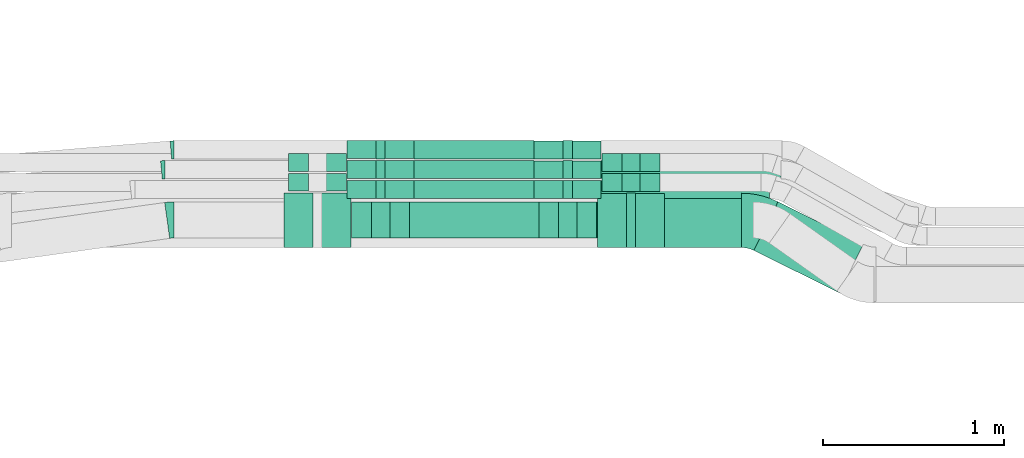
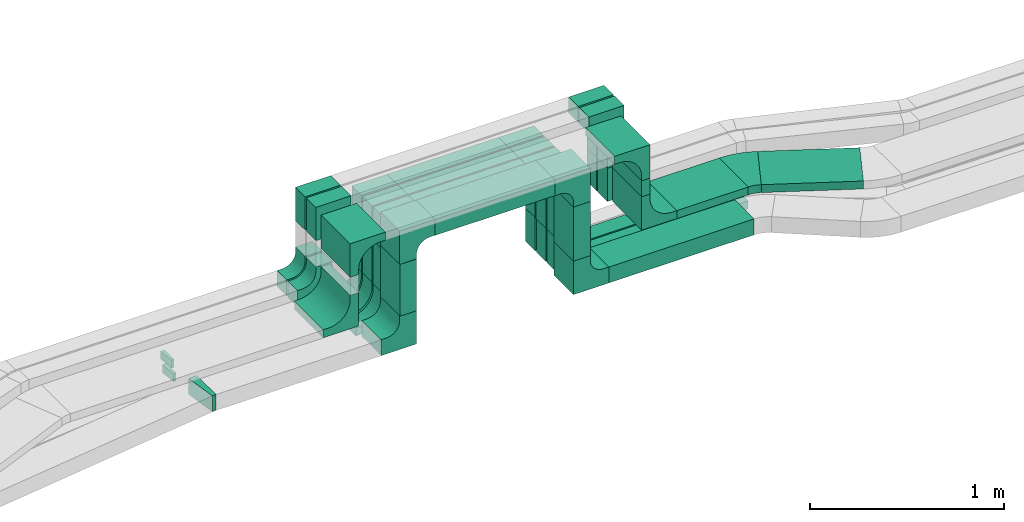
# One storey, part 17 of 33: 32 flow fittings, 20 flow segments.
"""IFC2X3 building model written with IfcOpenShell, lengths in millimetres."""

from ifc_helpers import new_model, entity, si_unit, converted_unit, derived_unit, direction, frame, frame_2d, origin, origin_2d_with_axis, place, context, subcontext, project, spatial, polyline, circle_curve, parameter, trimmed, segment, composite_curve, rectangle, outline, extrude, source, transform, mapped, material, type_object, type_shapes, element, save


model = new_model("IFC2X3")

# Units and contexts
model_context = context("Model", 3, precision=0.01, world=origin(), true_north=direction((6.12303176911189e-17, 1.0)))
body_context = subcontext(model_context, "Body", "Model", "MODEL_VIEW")
ifc_project = project(units=[si_unit("LENGTHUNIT", "METRE", prefix="MILLI"), si_unit("AREAUNIT", "SQUARE_METRE"), si_unit("VOLUMEUNIT", "CUBIC_METRE"), converted_unit("PLANEANGLEUNIT", "DEGREE", entity("IfcRatioMeasure", 0.0174532925199433), si_unit("PLANEANGLEUNIT", "RADIAN"), dimensions=[0, 0, 0, 0, 0, 0, 0]), si_unit("MASSUNIT", "GRAM", prefix="KILO"), derived_unit("MASSDENSITYUNIT", [(si_unit("MASSUNIT", "GRAM", prefix="KILO"), 1), (si_unit("LENGTHUNIT", "METRE"), -3)]), derived_unit("MOMENTOFINERTIAUNIT", [(si_unit("LENGTHUNIT", "METRE"), 4)]), si_unit("TIMEUNIT", "SECOND"), si_unit("FREQUENCYUNIT", "HERTZ"), si_unit("THERMODYNAMICTEMPERATUREUNIT", "DEGREE_CELSIUS"), derived_unit("THERMALTRANSMITTANCEUNIT", [(si_unit("MASSUNIT", "GRAM", prefix="KILO"), 1), (si_unit("THERMODYNAMICTEMPERATUREUNIT", "KELVIN"), -1), (si_unit("TIMEUNIT", "SECOND"), -3)]), derived_unit("VOLUMETRICFLOWRATEUNIT", [(si_unit("LENGTHUNIT", "METRE"), 3), (si_unit("TIMEUNIT", "SECOND"), -1)]), derived_unit("MASSFLOWRATEUNIT", [(si_unit("MASSUNIT", "GRAM", prefix="KILO"), 1), (si_unit("TIMEUNIT", "SECOND"), -1)]), derived_unit("ROTATIONALFREQUENCYUNIT", [(si_unit("TIMEUNIT", "SECOND"), -1)]), si_unit("ELECTRICCURRENTUNIT", "AMPERE"), si_unit("ELECTRICVOLTAGEUNIT", "VOLT"), si_unit("POWERUNIT", "WATT"), si_unit("FORCEUNIT", "NEWTON", prefix="KILO"), si_unit("ILLUMINANCEUNIT", "LUX"), si_unit("LUMINOUSFLUXUNIT", "LUMEN"), si_unit("LUMINOUSINTENSITYUNIT", "CANDELA"), derived_unit("USERDEFINED", [(si_unit("MASSUNIT", "GRAM", prefix="KILO"), -1), (si_unit("LENGTHUNIT", "METRE"), -2), (si_unit("TIMEUNIT", "SECOND"), 3), (si_unit("LUMINOUSFLUXUNIT", "LUMEN"), 1)]), derived_unit("LINEARVELOCITYUNIT", [(si_unit("LENGTHUNIT", "METRE"), 1), (si_unit("TIMEUNIT", "SECOND"), -1)]), si_unit("PRESSUREUNIT", "PASCAL"), derived_unit("USERDEFINED", [(si_unit("LENGTHUNIT", "METRE"), -2), (si_unit("MASSUNIT", "GRAM", prefix="KILO"), 1), (si_unit("TIMEUNIT", "SECOND"), -2)]), derived_unit("LINEARFORCEUNIT", [(si_unit("MASSUNIT", "GRAM", prefix="KILO"), 1), (si_unit("LENGTHUNIT", "METRE"), 1), (si_unit("TIMEUNIT", "SECOND"), -2), (si_unit("LENGTHUNIT", "METRE"), -1)]), derived_unit("PLANARFORCEUNIT", [(si_unit("MASSUNIT", "GRAM", prefix="KILO"), 1), (si_unit("LENGTHUNIT", "METRE"), 1), (si_unit("TIMEUNIT", "SECOND"), -2), (si_unit("LENGTHUNIT", "METRE"), -2)])], contexts=[model_context])

# Site, building, storey
site_placement = place(None, frame((0.0, -0.00077364408347762, 0.0)))
site = spatial("IfcSite", under=ifc_project, at=site_placement, CompositionType="ELEMENT")
building_placement = place(site_placement, origin())
building = spatial("IfcBuilding", under=site, at=building_placement, CompositionType="ELEMENT")
storey_placement = place(building_placement, frame((0.0, 0.0, 8100.0)))
storey = spatial("IfcBuildingStorey", under=building, at=storey_placement, CompositionType="ELEMENT", Elevation=8100.0)

# Flow segments
cable_carrier_segment_type = type_object("IfcCableCarrierSegmentType", PredefinedType="CABLETRAYSEGMENT")
flow_segment_1_placement = place(storey_placement, frame((30108.1990989324, 14532.2782357463, 3209.99867972438)))
element("IfcFlowSegment", 1, at=flow_segment_1_placement, inside=storey, type_object=cable_carrier_segment_type, context=body_context, shape_type="SweptSolid", body=[
    extrude(rectangle(XDim=713.213983371323, YDim=200.000000000002, at=origin_2d_with_axis()), frame((356.606991685662, 100.0, 0.0)), (0.0, 0.0, 1.0), 99.9999999999989),
])
flow_segment_2_placement = place(storey_placement, frame((29898.1990989324, 14532.2782357463, 2775.0)))
element("IfcFlowSegment", 2, at=flow_segment_2_placement, inside=storey, type_object=cable_carrier_segment_type, context=body_context, shape_type="SweptSolid", body=[
    extrude(rectangle(XDim=199.999999999998, YDim=100.000000000003, at=origin_2d_with_axis()), frame((50.0, 100.0, 0.0), z_axis=(0.0, 0.0, 1.0), x_axis=(0.0, 1.0, 0.0)), (0.0, 0.0, 1.0), 324.998679724392),
])
flow_segment_3_placement = place(storey_placement, frame((30931.4130823037, 14532.2782357463, 2758.87698397102)))
element("IfcFlowSegment", 3, at=flow_segment_3_placement, inside=storey, type_object=cable_carrier_segment_type, context=body_context, shape_type="SweptSolid", body=[
    extrude(rectangle(XDim=199.999999999998, YDim=100.000000000003, at=origin_2d_with_axis()), frame((50.0, 100.0, 0.0), z_axis=(0.0, 0.0, 1.0), x_axis=(0.0, -1.0, 0.0)), (0.0, 0.0, 1.0), 341.12169575336),
])
flow_segment_4_placement = place(storey_placement, frame((31166.4130823037, 14750.0572451366, 2548.879926104)))
element("IfcFlowSegment", 4, at=flow_segment_4_placement, inside=storey, type_object=cable_carrier_segment_type, context=body_context, shape_type="SweptSolid", body=[
    extrude(rectangle(XDim=930.329654405807, YDim=99.9999999999989, at=frame_2d((-2.1600499167107e-12, 0.0), x_axis=(1.0, 0.0))), frame((465.164827202906, 50.0, 0.0)), (0.0, 0.0, 1.0), 50.0000000000016),
])
flow_segment_5_placement = place(storey_placement, frame((30133.1990989324, 14750.0572451365, 3209.99867972438)))
element("IfcFlowSegment", 5, at=flow_segment_5_placement, inside=storey, type_object=cable_carrier_segment_type, context=body_context, shape_type="SweptSolid", body=[
    extrude(rectangle(XDim=663.2139833713, YDim=99.9999999999989, at=origin_2d_with_axis()), frame((331.60699168565, 50.0, 0.0)), (0.0, 0.0, 1.0), 50.0000000000016),
])
flow_segment_6_placement = place(storey_placement, frame((29923.1990989324, 14750.0572451365, 2775.34290576127)))
element("IfcFlowSegment", 6, at=flow_segment_6_placement, inside=storey, type_object=cable_carrier_segment_type, context=body_context, shape_type="SweptSolid", body=[
    extrude(rectangle(XDim=99.9999999999989, YDim=49.9999999999973, at=origin_2d_with_axis()), frame((25.0, 50.0, 0.0), z_axis=(0.0, 0.0, 1.0), x_axis=(0.0, 1.0, 0.0)), (0.0, 0.0, 1.0), 274.655773963117),
])
flow_segment_7_placement = place(storey_placement, frame((30956.4130823037, 14750.0572451365, 2758.87992610398)))
element("IfcFlowSegment", 7, at=flow_segment_7_placement, inside=storey, type_object=cable_carrier_segment_type, context=body_context, shape_type="SweptSolid", body=[
    extrude(rectangle(XDim=99.9999999999989, YDim=49.9999999999973, at=frame_2d((-2.16715534406831e-12, 0.0), x_axis=(1.0, 0.0))), frame((25.0, 50.0, 0.0), z_axis=(0.0, 0.0, 1.0), x_axis=(0.0, -1.0, 0.0)), (0.0, 0.0, 1.0), 291.118753620383),
])
flow_segment_8_placement = place(storey_placement, frame((30133.1990989324, 14860.0572451365, 3209.99867972438)))
element("IfcFlowSegment", 8, at=flow_segment_8_placement, inside=storey, type_object=cable_carrier_segment_type, context=body_context, shape_type="SweptSolid", body=[
    extrude(rectangle(XDim=663.2139833713, YDim=99.9999999999989, at=origin_2d_with_axis()), frame((331.60699168565, 50.0, 0.0)), (0.0, 0.0, 1.0), 50.0000000000016),
])
flow_segment_9_placement = place(storey_placement, frame((29923.1990989324, 14860.0572451365, 2780.0)))
element("IfcFlowSegment", 9, at=flow_segment_9_placement, inside=storey, type_object=cable_carrier_segment_type, context=body_context, shape_type="SweptSolid", body=[
    extrude(rectangle(XDim=99.9999999999989, YDim=49.9999999999973, at=origin_2d_with_axis()), frame((25.0, 50.0, 0.0), z_axis=(0.0, 0.0, 1.0), x_axis=(0.0, 1.0, 0.0)), (0.0, 0.0, 1.0), 269.998679724392),
])
flow_segment_10_placement = place(storey_placement, frame((30956.4130823037, 14860.0572451365, 2758.34838425102)))
element("IfcFlowSegment", 10, at=flow_segment_10_placement, inside=storey, type_object=cable_carrier_segment_type, context=body_context, shape_type="SweptSolid", body=[
    extrude(rectangle(XDim=99.9999999999989, YDim=49.9999999999973, at=origin_2d_with_axis()), frame((25.0, 50.0, 0.0), z_axis=(0.0, 0.0, 1.0), x_axis=(0.0, -1.0, 0.0)), (0.0, 0.0, 1.0), 291.650295473346),
])
flow_segment_11_placement = place(storey_placement, frame((30133.1990989324, 14970.0572451365, 3209.99867972438)))
element("IfcFlowSegment", 11, at=flow_segment_11_placement, inside=storey, type_object=cable_carrier_segment_type, context=body_context, shape_type="SweptSolid", body=[
    extrude(rectangle(XDim=663.2139833713, YDim=99.9999999999989, at=origin_2d_with_axis()), frame((331.60699168565, 50.0, 0.0)), (0.0, 0.0, 1.0), 50.0000000000016),
])
flow_segment_12_placement = place(storey_placement, frame((29923.1990989324, 14970.0572451365, 2780.0)))
element("IfcFlowSegment", 12, at=flow_segment_12_placement, inside=storey, type_object=cable_carrier_segment_type, context=body_context, shape_type="SweptSolid", body=[
    extrude(rectangle(XDim=99.9999999999989, YDim=49.9999999999973, at=origin_2d_with_axis()), frame((25.0, 50.0, 0.0), z_axis=(0.0, 0.0, 1.0), x_axis=(0.0, 1.0, 0.0)), (0.0, 0.0, 1.0), 269.998679724392),
])
flow_segment_13_placement = place(storey_placement, frame((30956.4130823037, 14970.0572451365, 2758.86724903675)))
element("IfcFlowSegment", 13, at=flow_segment_13_placement, inside=storey, type_object=cable_carrier_segment_type, context=body_context, shape_type="SweptSolid", body=[
    extrude(rectangle(XDim=99.9999999999989, YDim=49.9999999999973, at=frame_2d((-2.16715534406831e-12, 0.0), x_axis=(1.0, 0.0))), frame((25.0, 50.0, 0.0), z_axis=(0.0, 0.0, 1.0), x_axis=(0.0, -1.0, 0.0)), (0.0, 0.0, 1.0), 291.131430687611),
])
for number, where in (
    (14, (31281.4130823037, 14900.0572451365, 3065.0)),
    (15, (31281.4130823037, 14790.0572451365, 3065.0)),
):
    element("IfcFlowSegment", number, at=place(storey_placement, frame(where)), inside=storey, type_object=cable_carrier_segment_type, context=body_context, shape_type="SweptSolid", body=[
        extrude(rectangle(XDim=99.9999999999989, YDim=100.000000000003, at=origin_2d_with_axis()), frame((50.0, 50.0, 0.0), z_axis=(0.0, 0.0, 1.0), x_axis=(0.0, -1.0, 0.0)), (0.0, 0.0, 1.0), 149.998679724358),
    ])
flow_segment_14_placement = place(storey_placement, frame((31306.4130823037, 14480.0572451366, 3064.49733895661)))
element("IfcFlowSegment", 16, at=flow_segment_14_placement, inside=storey, type_object=cable_carrier_segment_type, context=body_context, shape_type="SweptSolid", body=[
    extrude(rectangle(XDim=300.000000000001, YDim=49.9999999999973, at=origin_2d_with_axis()), frame((25.0, 150.0, 0.0), z_axis=(0.0, 0.0, 1.0), x_axis=(0.0, -1.0, 0.0)), (0.0, 0.0, 1.0), 100.501340766892),
])
flow_segment_15_placement = place(storey_placement, frame((31516.4130823037, 14480.0572451372, 2854.49733895749)))
element("IfcFlowSegment", 17, at=flow_segment_15_placement, inside=storey, type_object=cable_carrier_segment_type, context=body_context, shape_type="SweptSolid", body=[
    extrude(rectangle(XDim=424.417391840432, YDim=300.000000000001, at=frame_2d((-2.17426077142591e-12, 0.0), x_axis=(1.0, 0.0))), frame((212.208695920218, 150.0, 0.0)), (0.0, 0.0, 1.0), 50.0000000000016),
])
flow_segment_16_placement = place(storey_placement, frame((31166.4130823038, 14860.0572451366, 2548.34838425104)))
element("IfcFlowSegment", 18, at=flow_segment_16_placement, inside=storey, type_object=cable_carrier_segment_type, context=body_context, shape_type="SweptSolid", body=[
    extrude(rectangle(XDim=992.779967028208, YDim=99.9999999999989, at=frame_2d((0.0, -1.08357767203415e-12), x_axis=(1.0, 0.0))), frame((496.389983514104, 50.0, 0.0), z_axis=(0.0, 0.0, 1.0), x_axis=(-1.0, 0.0, 0.0)), (0.0, 0.0, 1.0), 50.0000000000016),
])
flow_segment_17_placement = place(storey_placement, frame((31141.4130823037, 14532.2782357463, 2548.87698397102)))
element("IfcFlowSegment", 19, at=flow_segment_17_placement, inside=storey, type_object=cable_carrier_segment_type, context=body_context, shape_type="SweptSolid", body=[
    extrude(rectangle(XDim=864.32109174626, YDim=199.999999999998, at=frame_2d((2.1600499167107e-12, 0.0), x_axis=(1.0, 0.0))), frame((432.160545873128, 100.0, 0.0)), (0.0, 0.0, 1.0), 99.9999999999989),
])
flow_segment_18_placement = place(storey_placement, frame((32009.4138818101, 14229.6412017513, 2854.49733895749)))
element("IfcFlowSegment", 20, at=flow_segment_18_placement, inside=storey, type_object=cable_carrier_segment_type, context=body_context, shape_type="SweptSolid", body=[
    extrude(rectangle(XDim=527.080933740967, YDim=299.999999999999, at=frame_2d((4.83169060316868e-13, -9.66338120633736e-13), x_axis=(1.0, 0.0))), frame((302.750599442207, 251.526538690857, 0.0), z_axis=(0.0, 0.0, 1.0), x_axis=(-0.895736929927625, 0.444584471572987, 0.0)), (0.0, 0.0, 1.0), 50.0000000000016),
])

# Flow fittings
ifc_material = material()
cable_carrier_fitting_type_1 = type_object("IfcCableCarrierFittingType", Name="470_DKC_S5_CDV 90 external vertical angle:-", PredefinedType="NOTDEFINED", material=ifc_material)
shared_shape_1 = source(origin(), body_context, "Body", "SweptSolid", [
    extrude(outline(composite_curve([segment(polyline([(65.7142857142854, 14.2857142857149), (95.7142857142855, 14.2857142857149)]), True, "CONTINUOUS"), segment(polyline([(95.7142857142855, 14.2857142857149), (95.7142857142855, 114.285714285713)]), True, "CONTINUOUS"), segment(polyline([(95.7142857142855, 114.285714285713), (-114.285714285714, 114.285714285713)]), True, "CONTINUOUS"), segment(polyline([(-114.285714285714, 114.285714285713), (-114.285714285714, -95.7142857142853)]), True, "CONTINUOUS"), segment(polyline([(-114.285714285714, -95.7142857142853), (-14.2857142857144, -95.7142857142853)]), True, "CONTINUOUS"), segment(polyline([(-14.2857142857145, -95.7142857142853), (-14.2857142857145, -65.7142857142849)]), True, "CONTINUOUS"), segment(trimmed(circle_curve(frame_2d((65.7142857142855, -65.714285714285), x_axis=(-1.0, 0.0)), 80.0), [parameter(270.0)], [parameter(2.54444374517082e-13)], True, "PARAMETER"), False, "CONTINUOUS")], self_intersect=False)), frame((-64.2857142857073, 64.2857142857068, -99.0), z_axis=(0.0, 0.0, 1.0), x_axis=(-1.0, 0.0, 0.0)), (0.0, 0.0, 1.0), 199.0),
])
type_shapes(cable_carrier_fitting_type_1, [shared_shape_1])
for number, where, z_axis, x_axis, name in (
    (21, (29948.1990989324, 14632.2782357463, 3259.99867972437), (0.0, 1.0, 0.0), (0.0, 0.0, 1.0), "470_DKC_S5_90 external vertical angle"),
    (22, (30981.4130823037, 14632.2782357463, 3259.99867972437), (0.0, -1.0, 0.0), (0.0, 0.0, 1.0), "470_DKC_S5_90 external vertical angle"),
    (23, (30981.4130823038, 14632.2782357463, 2598.87698397103), (0.0, -1.0, 0.0), (0.0, 0.0, -1.0), "470_DKC_S5_90 external vertical angle"),
    (24, (29948.1990989324, 14632.2782357463, 2615.0), (0.0, 1.0, 0.0), (0.0, 0.0, -1.0), "470_DKC_S5_90 external vertical angle"),
):
    element("IfcFlowFitting", number, at=place(storey_placement, frame(where, z_axis=z_axis, x_axis=x_axis)), inside=storey, type_object=cable_carrier_fitting_type_1, material=ifc_material, Name=name, ObjectType="470_DKC_S5_CDV 90 external vertical angle:-", context=body_context, shape_type="MappedRepresentation", body=[
        mapped(shared_shape_1, transform((0.0, 0.0, 0.0), scale=1.0)),
    ])
cable_carrier_fitting_type_2 = type_object("IfcCableCarrierFittingType", Name="470_DKC_S5_CDV 90 external vertical angle:-", PredefinedType="NOTDEFINED", material=ifc_material)
shared_shape_2 = source(origin(), body_context, "Body", "SweptSolid", [
    extrude(outline(composite_curve([segment(polyline([(80.0, 50.0), (110.0, 50.0)]), True, "CONTINUOUS"), segment(polyline([(110.0, 50.0), (110.0, 100.0)]), True, "CONTINUOUS"), segment(polyline([(110.0, 100.0), (-100.0, 100.0)]), True, "CONTINUOUS"), segment(polyline([(-100.0, 100.0), (-100.0, -110.0)]), True, "CONTINUOUS"), segment(polyline([(-100.0, -110.0), (-50.0, -110.0)]), True, "CONTINUOUS"), segment(polyline([(-50.0, -110.0), (-50.0, -80.0)]), True, "CONTINUOUS"), segment(trimmed(circle_curve(frame_2d((80.0, -80.0), x_axis=(-1.0, 0.0)), 130.0), [parameter(270.0)], [parameter(2.54444374517082e-13)], True, "PARAMETER"), False, "CONTINUOUS")], self_intersect=False)), frame((-75.0, 75.0, -49.0), z_axis=(0.0, 0.0, 1.0), x_axis=(-1.0, 0.0, 0.0)), (0.0, 0.0, 1.0), 99.0000000000002),
])
type_shapes(cable_carrier_fitting_type_2, [shared_shape_2])
for number, where, z_axis, x_axis, name in (
    (25, (29948.1990989325, 14800.0572451365, 3234.99867972437), (0.0, 1.0, 0.0), (0.0, 0.0, 1.0), "470_DKC_S5_90 external vertical angle"),
    (26, (30981.4130823037, 14800.0572451365, 3234.99867972437), (0.0, -1.0, 0.0), (0.0, 0.0, 1.0), "470_DKC_S5_90 external vertical angle"),
    (27, (29948.1990989325, 14910.0572451365, 3234.99867972437), (0.0, 1.0, 0.0), (0.0, 0.0, 1.0), "470_DKC_S5_90 external vertical angle"),
    (28, (30981.4130823037, 14910.0572451365, 3234.99867972437), (0.0, -1.0, 0.0), (0.0, 0.0, 1.0), "470_DKC_S5_90 external vertical angle"),
    (29, (29948.1990989325, 15020.0572451365, 3234.99867972437), (0.0, 1.0, 0.0), (0.0, 0.0, 1.0), "470_DKC_S5_90 external vertical angle"),
    (30, (30981.4130823037, 15020.0572451365, 3234.99867972437), (0.0, -1.0, 0.0), (0.0, 0.0, 1.0), "470_DKC_S5_90 external vertical angle"),
    (31, (30981.4130823038, 14910.0572451366, 2573.34838425105), (0.0, -1.0, 0.0), (0.0, 0.0, -1.0), "470_DKC_S5_90 external vertical angle"),
    (32, (30981.4130823038, 14800.0572451366, 2573.87992610402), (0.0, -1.0, 0.0), (0.0, 0.0, -1.0), "470_DKC_S5_90 external vertical angle"),
    (33, (30981.4130823038, 15020.0572451366, 2573.86724903679), (0.0, -1.0, 0.0), (0.0, 0.0, -1.0), "470_DKC_S5_90 external vertical angle"),
    (34, (29948.1990989324, 14800.0572451365, 2590.34290576128), (0.0, 1.0, 0.0), (0.0, 0.0, -1.0), "470_DKC_S5_90 external vertical angle"),
    (35, (29948.1990989324, 15020.0572451365, 2595.0), (0.0, 1.0, 0.0), (0.0, 0.0, -1.0), "470_DKC_S5_90 external vertical angle"),
    (36, (29948.1990989324, 14910.0572451365, 2595.0), (0.0, 1.0, 0.0), (0.0, 0.0, -1.0), "470_DKC_S5_90 external vertical angle"),
):
    element("IfcFlowFitting", number, at=place(storey_placement, frame(where, z_axis=z_axis, x_axis=x_axis)), inside=storey, type_object=cable_carrier_fitting_type_2, material=ifc_material, Name=name, ObjectType="470_DKC_S5_CDV 90 external vertical angle:-", context=body_context, shape_type="MappedRepresentation", body=[
        mapped(shared_shape_2, transform((0.0, 0.0, 0.0), scale=1.0)),
    ])
cable_carrier_fitting_type_3 = type_object("IfcCableCarrierFittingType", Name="470_DKC_S5_CDV 90 external vertical angle:-", PredefinedType="NOTDEFINED", material=ifc_material)
shared_shape_3 = source(origin(), body_context, "Body", "SweptSolid", [
    extrude(outline(composite_curve([segment(polyline([(65.7142857142854, 14.2857142857149), (95.7142857142855, 14.2857142857149)]), True, "CONTINUOUS"), segment(polyline([(95.7142857142855, 14.2857142857149), (95.7142857142855, 114.285714285713)]), True, "CONTINUOUS"), segment(polyline([(95.7142857142855, 114.285714285713), (-114.285714285714, 114.285714285713)]), True, "CONTINUOUS"), segment(polyline([(-114.285714285714, 114.285714285713), (-114.285714285714, -95.7142857142853)]), True, "CONTINUOUS"), segment(polyline([(-114.285714285714, -95.7142857142853), (-14.2857142857144, -95.7142857142853)]), True, "CONTINUOUS"), segment(polyline([(-14.2857142857145, -95.7142857142853), (-14.2857142857145, -65.7142857142849)]), True, "CONTINUOUS"), segment(trimmed(circle_curve(frame_2d((65.7142857142855, -65.714285714285), x_axis=(-1.0, 0.0)), 80.0), [parameter(270.0)], [parameter(2.54444374517082e-13)], True, "PARAMETER"), False, "CONTINUOUS")], self_intersect=False)), frame((-64.2857142857073, 64.2857142857068, -49.0), z_axis=(0.0, 0.0, 1.0), x_axis=(-1.0, 0.0, 0.0)), (0.0, 0.0, 1.0), 99.0000000000002),
])
type_shapes(cable_carrier_fitting_type_3, [shared_shape_3])
for number, where, z_axis, x_axis, name in (
    (37, (29598.1990989325, 14950.0572451365, 3374.99867972437), (0.0, 1.0, 0.0), (0.0, 0.0, 1.0), "470_DKC_S5_90 external vertical angle"),
    (38, (31331.4130823037, 14950.0572451365, 3374.99867972437), (0.0, -1.0, 0.0), (0.0, 0.0, 1.0), "470_DKC_S5_90 external vertical angle"),
    (39, (29598.1990989325, 14840.0572451365, 3374.99867972437), (0.0, 1.0, 0.0), (0.0, 0.0, 1.0), "470_DKC_S5_90 external vertical angle"),
    (40, (31331.4130823037, 14840.0572451365, 3374.99867972437), (0.0, -1.0, 0.0), (0.0, 0.0, 1.0), "470_DKC_S5_90 external vertical angle"),
    (41, (29598.1990989324, 14840.0572451365, 2890.0), (0.0, 1.0, 0.0), (0.0, 0.0, -1.0), "470_DKC_S5_90 external vertical angle"),
    (42, (29598.1990989324, 14950.0572451365, 2890.0), (0.0, 1.0, 0.0), (0.0, 0.0, -1.0), "470_DKC_S5_90 external vertical angle"),
    (43, (31331.4130823038, 14950.0572451367, 2905.0), (0.0, -1.0, 0.0), (0.0, 0.0, -1.0), "470_DKC_S5_90 external vertical angle"),
    (44, (31331.4130823038, 14840.0572451367, 2905.0), (0.0, -1.0, 0.0), (0.0, 0.0, -1.0), "470_DKC_S5_90 external vertical angle"),
):
    element("IfcFlowFitting", number, at=place(storey_placement, frame(where, z_axis=z_axis, x_axis=x_axis)), inside=storey, type_object=cable_carrier_fitting_type_3, material=ifc_material, Name=name, ObjectType="470_DKC_S5_CDV 90 external vertical angle:-", context=body_context, shape_type="MappedRepresentation", body=[
        mapped(shared_shape_3, transform((0.0, 0.0, 0.0), scale=1.0)),
    ])
cable_carrier_fitting_type_4 = type_object("IfcCableCarrierFittingType", Name="470_DKC_S5_CDV 90 external vertical angle:-", PredefinedType="NOTDEFINED", material=ifc_material)
shared_shape_4 = source(origin(), body_context, "Body", "SweptSolid", [
    extrude(outline(composite_curve([segment(polyline([(80.0, 50.0), (110.0, 50.0)]), True, "CONTINUOUS"), segment(polyline([(110.0, 50.0), (110.0, 100.0)]), True, "CONTINUOUS"), segment(polyline([(110.0, 100.0), (-100.0, 100.0)]), True, "CONTINUOUS"), segment(polyline([(-100.0, 100.0), (-100.0, -110.0)]), True, "CONTINUOUS"), segment(polyline([(-100.0, -110.0), (-50.0, -110.0)]), True, "CONTINUOUS"), segment(polyline([(-50.0, -110.0), (-50.0, -80.0)]), True, "CONTINUOUS"), segment(trimmed(circle_curve(frame_2d((80.0, -80.0), x_axis=(-1.0, 0.0)), 130.0), [parameter(270.0)], [parameter(2.54444374517082e-13)], True, "PARAMETER"), False, "CONTINUOUS")], self_intersect=False)), frame((-75.0, 75.0, -149.0), z_axis=(0.0, 0.0, 1.0), x_axis=(-1.0, 0.0, 0.0)), (0.0, 0.0, 1.0), 299.0),
])
type_shapes(cable_carrier_fitting_type_4, [shared_shape_4])
for number, where, z_axis, x_axis, name in (
    (45, (29598.1990989325, 14630.0572451366, 3349.99867972437), (0.0, 1.0, 0.0), (0.0, 0.0, 1.0), "470_DKC_S5_90 external vertical angle"),
    (46, (31331.4130823037, 14630.0572451366, 3349.99867972437), (0.0, -1.0, 0.0), (0.0, 0.0, 1.0), "470_DKC_S5_90 external vertical angle"),
    (47, (29598.1990989324, 14630.0572451366, 2865.01712441884), (0.0, 1.0, 0.0), (0.0, 0.0, -1.0), "470_DKC_S5_90 external vertical angle"),
    (48, (31331.4130823038, 14630.0572451372, 2879.49733895751), (0.0, -1.0, 0.0), (0.0, 0.0, -1.0), "470_DKC_S5_90 external vertical angle"),
):
    element("IfcFlowFitting", number, at=place(storey_placement, frame(where, z_axis=z_axis, x_axis=x_axis)), inside=storey, type_object=cable_carrier_fitting_type_4, material=ifc_material, Name=name, ObjectType="470_DKC_S5_CDV 90 external vertical angle:-", context=body_context, shape_type="MappedRepresentation", body=[
        mapped(shared_shape_4, transform((0.0, 0.0, 0.0), scale=1.0)),
    ])
cable_carrier_fitting_type_5 = type_object("IfcCableCarrierFittingType", Name="470_DKC_S5_Variable Angle Elbow 0-45:-", PredefinedType="NOTDEFINED", material=ifc_material)
shared_shape_5 = source(origin(), body_context, "Body", "SweptSolid", [
    extrude(outline(composite_curve([segment(polyline([(-67.6616049684268, -165.75060662875), (-66.6616049684255, -165.75060662875)]), True, "CONTINUOUS"), segment(trimmed(circle_curve(frame_2d((-66.6616049684336, 284.24939337125), x_axis=(0.0, -1.0)), 450.0), [parameter(0.0)], [parameter(26.3967564439115)], True, "PARAMETER"), True, "CONTINUOUS"), segment(polyline([(133.401407239414, -118.83222509618), (134.297144169341, -118.387640624607)]), True, "CONTINUOUS"), segment(polyline([(134.297144169341, -118.387640624607), (0.921802697443936, 150.33343835368)]), True, "CONTINUOUS"), segment(polyline([(0.921802697443919, 150.33343835368), (0.0260657675154811, 149.888853882107)]), True, "CONTINUOUS"), segment(trimmed(circle_curve(frame_2d((-66.6616049684336, 284.24939337125), x_axis=(0.0, -1.0)), 150.0), [parameter(0.0)], [parameter(26.3967564439115)], True, "PARAMETER"), False, "CONTINUOUS"), segment(polyline([(-66.6616049684306, 134.24939337125), (-67.6616049684319, 134.24939337125)]), True, "CONTINUOUS"), segment(polyline([(-67.6616049684319, 134.24939337125), (-67.6616049684268, -165.75060662875)]), True, "CONTINUOUS")], self_intersect=False)), frame((-3.69380108306741, 15.7506066287408, -25.0)), (0.0, 0.0, 1.0), 49.999999999999),
])
type_shapes(cable_carrier_fitting_type_5, [shared_shape_5])
flow_fitting_1_placement = place(storey_placement, frame((32012.1858801957, 14630.0572451371, 2879.49733895749), z_axis=(0.0, 0.0, 1.0), x_axis=(-0.895736929927626, 0.444584471572987, 0.0)))
element("IfcFlowFitting", 49, at=flow_fitting_1_placement, inside=storey, type_object=cable_carrier_fitting_type_5, material=ifc_material, Name="470_DKC_S5_Variable Angle Elbow 0-45:-", ObjectType="470_DKC_S5_Variable Angle Elbow 0-45:-", context=body_context, shape_type="MappedRepresentation", body=[
    mapped(shared_shape_5, transform((0.0, 0.0, 0.0), scale=1.0)),
])
cable_carrier_fitting_type_6 = type_object("IfcCableCarrierFittingType", Name="470_DKC_S5_Variable Angle Elbow 0-45:-", PredefinedType="NOTDEFINED", material=ifc_material)
shared_shape_6 = source(origin(), body_context, "Body", "SweptSolid", [
    extrude(outline(composite_curve([segment(polyline([(-10.155602411636, -50.4429955087325), (-9.15560241163469, -50.4429955087325)]), True, "CONTINUOUS"), segment(trimmed(circle_curve(frame_2d((-9.15560241163514, 199.557004491267), x_axis=(0.0, -1.0)), 250.0), [parameter(0.0)], [parameter(5.25373463552036)], True, "PARAMETER"), True, "CONTINUOUS"), segment(polyline([(13.7360292666842, -49.3927358160969), (14.7318282279136, -49.3011692893836)]), True, "CONTINUOUS"), segment(polyline([(14.7318282279136, -49.3011692893836), (5.575175556586, 50.278726833562)]), True, "CONTINUOUS"), segment(polyline([(5.57517555658601, 50.278726833562), (4.57937659535649, 50.1871603068488)]), True, "CONTINUOUS"), segment(trimmed(circle_curve(frame_2d((-9.15560241163514, 199.557004491267), x_axis=(0.0, -1.0)), 150.0), [parameter(0.0)], [parameter(5.25373463552036)], True, "PARAMETER"), False, "CONTINUOUS"), segment(polyline([(-9.15560241163469, 49.5570044912674), (-10.155602411636, 49.5570044912674)]), True, "CONTINUOUS"), segment(polyline([(-10.155602411636, 49.5570044912674), (-10.155602411636, -50.4429955087325)]), True, "CONTINUOUS")], self_intersect=False)), frame((-0.0203244719797119, 0.44299550872446, -25.0)), (0.0, 0.0, 1.0), 50.0000000000002),
])
type_shapes(cable_carrier_fitting_type_6, [shared_shape_6])
flow_fitting_2_placement = place(storey_placement, frame((28746.7958294126, 14910.0572451365, 2595.0), z_axis=(0.0, 0.0, 1.0), x_axis=(-1.0, 0.0, 0.0)))
element("IfcFlowFitting", 50, at=flow_fitting_2_placement, inside=storey, type_object=cable_carrier_fitting_type_6, material=ifc_material, Name="470_DKC_S5_Variable Angle Elbow 0-45:-", ObjectType="470_DKC_S5_Variable Angle Elbow 0-45:-", context=body_context, shape_type="MappedRepresentation", body=[
    mapped(shared_shape_6, transform((0.0, 0.0, 0.0), scale=1.0)),
])
cable_carrier_fitting_type_7 = type_object("IfcCableCarrierFittingType", Name="470_DKC_S5_Variable Angle Elbow 0-45:-", PredefinedType="NOTDEFINED", material=ifc_material)
shared_shape_7 = source(origin(), body_context, "Body", "SweptSolid", [
    extrude(outline(composite_curve([segment(polyline([(-9.17792586537339, -50.3554689628789), (-8.17792586537208, -50.3554689628789)]), True, "CONTINUOUS"), segment(trimmed(circle_curve(frame_2d((-8.17792586537254, 199.644531037121), x_axis=(0.0, -1.0)), 250.0), [parameter(0.0)], [parameter(4.69132642007995)], True, "PARAMETER"), True, "CONTINUOUS"), segment(polyline([(12.2689826858983, -49.5179138270597), (13.2656324653548, -49.4361261928547)]), True, "CONTINUOUS"), segment(polyline([(13.2656324653548, -49.4361261928546), (5.08686904484686, 50.2288517528176)]), True, "CONTINUOUS"), segment(polyline([(5.08686904484686, 50.2288517528176), (4.09021926538994, 50.1470641186125)]), True, "CONTINUOUS"), segment(trimmed(circle_curve(frame_2d((-8.17792586537254, 199.644531037121), x_axis=(0.0, -1.0)), 150.0), [parameter(0.0)], [parameter(4.69132642007995)], True, "PARAMETER"), False, "CONTINUOUS"), segment(polyline([(-8.17792586537208, 49.644531037121), (-9.17792586537339, 49.644531037121)]), True, "CONTINUOUS"), segment(polyline([(-9.17792586537339, 49.644531037121), (-9.17792586537339, -50.3554689628789)]), True, "CONTINUOUS")], self_intersect=False)), frame((-0.0145608738130905, 0.355468962870826, -25.0)), (0.0, 0.0, 1.0), 50.0000000000002),
])
type_shapes(cable_carrier_fitting_type_7, [shared_shape_7])
flow_fitting_3_placement = place(storey_placement, frame((28798.0176900881, 15020.0572451365, 2595.0), z_axis=(0.0, 0.0, 1.0), x_axis=(-1.0, 0.0, 0.0)))
element("IfcFlowFitting", 51, at=flow_fitting_3_placement, inside=storey, type_object=cable_carrier_fitting_type_7, material=ifc_material, Name="470_DKC_S5_Variable Angle Elbow 0-45:-", ObjectType="470_DKC_S5_Variable Angle Elbow 0-45:-", context=body_context, shape_type="MappedRepresentation", body=[
    mapped(shared_shape_7, transform((0.0, 0.0, 0.0), scale=1.0)),
])
cable_carrier_fitting_type_8 = type_object("IfcCableCarrierFittingType", Name="470_DKC_S5_Variable Angle Elbow 0-45:-", PredefinedType="NOTDEFINED", material=ifc_material)
shared_shape_8 = source(origin(), body_context, "Body", "SweptSolid", [
    extrude(outline(composite_curve([segment(polyline([(-18.3731451150366, -101.248283825014), (-17.3731451150352, -101.248283825014)]), True, "CONTINUOUS"), segment(trimmed(circle_curve(frame_2d((-17.3731451150358, 248.751716174986), x_axis=(0.0, -1.0)), 350.0), [parameter(0.0)], [parameter(7.99024953832981)], True, "PARAMETER"), True, "CONTINUOUS"), segment(polyline([(31.2784569900759, -97.8503923191857), (32.2687487286304, -97.7113877417426)]), True, "CONTINUOUS"), segment(polyline([(32.2687487286304, -97.7113877417425), (4.46783323999563, 100.346959969213)]), True, "CONTINUOUS"), segment(polyline([(4.46783323999562, 100.346959969213), (3.47754150144062, 100.20795539177)]), True, "CONTINUOUS"), segment(trimmed(circle_curve(frame_2d((-17.3731451150358, 248.751716174986), x_axis=(0.0, -1.0)), 150.0), [parameter(0.0)], [parameter(7.99024953832981)], True, "PARAMETER"), False, "CONTINUOUS"), segment(polyline([(-17.3731451150352, 98.7517161749863), (-18.3731451150366, 98.7517161749863)]), True, "CONTINUOUS"), segment(polyline([(-18.3731451150366, 98.7517161749863), (-18.3731451150366, -101.248283825014)]), True, "CONTINUOUS")], self_intersect=False)), frame((-0.0871817745329385, 1.2482838250055, -50.0)), (0.0, 0.0, 1.0), 100.0),
])
type_shapes(cable_carrier_fitting_type_8, [shared_shape_8])
flow_fitting_4_placement = place(storey_placement, frame((28786.715018965, 14632.2782357464, 2615.0), z_axis=(0.0, -8.61527627208902e-06, 1.0), x_axis=(-1.0, 0.0, 0.0)))
element("IfcFlowFitting", 52, at=flow_fitting_4_placement, inside=storey, type_object=cable_carrier_fitting_type_8, material=ifc_material, Name="470_DKC_S5_Variable Angle Elbow 0-45:-", ObjectType="470_DKC_S5_Variable Angle Elbow 0-45:-", context=body_context, shape_type="MappedRepresentation", body=[
    mapped(shared_shape_8, transform((0.0, 0.0, 0.0), scale=1.0)),
])

save(model, "model.ifc")
